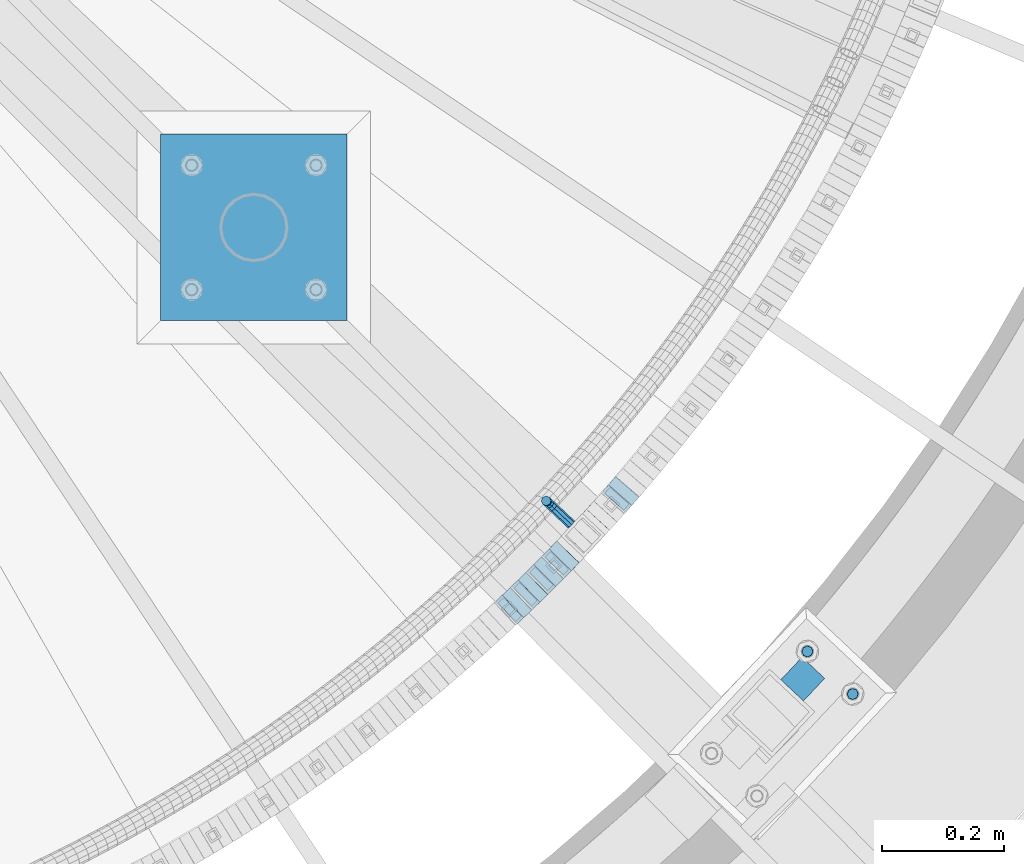
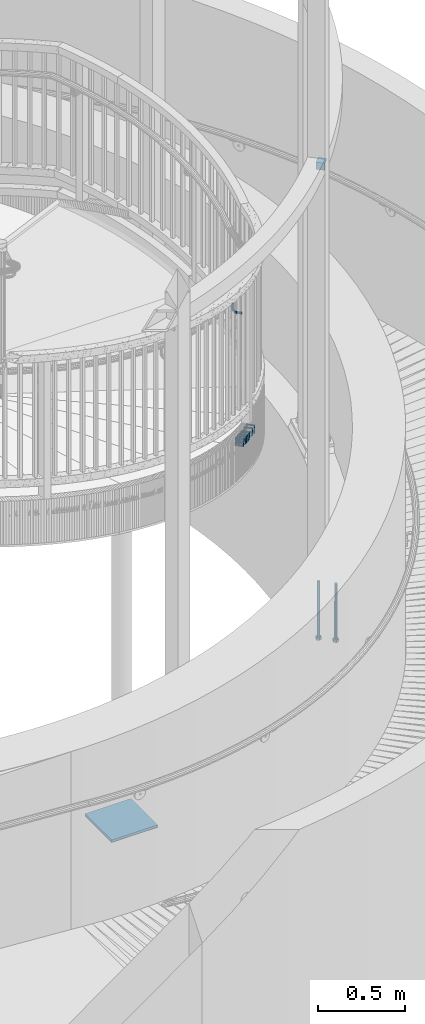
# One storey, part 492 of 975: 14 beams.
"""IFC2X3 building model written with IfcOpenShell, lengths in millimetres."""

from ifc_helpers import new_model, si_unit, frame, origin_with_axes, place, context, subcontext, project, spatial, faceted_brep, material, type_object, element, save


model = new_model("IFC2X3")

# Units and contexts
model_context = context("Model", 3, precision=1e-05, world=origin_with_axes())
body_context = subcontext(model_context, "Body", "Model", "MODEL_VIEW")
ifc_project = project(units=[si_unit("LENGTHUNIT", "METRE", prefix="MILLI"), si_unit("AREAUNIT", "SQUARE_METRE"), si_unit("VOLUMEUNIT", "CUBIC_METRE"), si_unit("MASSUNIT", "GRAM", prefix="KILO"), si_unit("TIMEUNIT", "SECOND"), si_unit("PLANEANGLEUNIT", "RADIAN"), si_unit("SOLIDANGLEUNIT", "STERADIAN"), si_unit("THERMODYNAMICTEMPERATUREUNIT", "DEGREE_CELSIUS"), si_unit("LUMINOUSINTENSITYUNIT", "LUMEN")], contexts=[model_context])

# Site, building, storey
site_placement = place(None, origin_with_axes())
site = spatial("IfcSite", under=ifc_project, at=site_placement, CompositionType="ELEMENT")
building_placement = place(site_placement, origin_with_axes())
building = spatial("IfcBuilding", under=site, at=building_placement, Name="Undefined", CompositionType="ELEMENT")
storey_placement = place(building_placement, origin_with_axes())
storey = spatial("IfcBuildingStorey", under=building, at=storey_placement, Name="Undefined", CompositionType="ELEMENT", Elevation=0.0)

# Beams
ifc_material_1 = material(Name="STEEL/A36")
beam_type_1 = type_object("IfcBeamType", PredefinedType="NOTDEFINED")
beam_1_placement = place(storey_placement, frame((36808.9338042328, 1456.90756596393, 3379.82813871674), z_axis=(0.0, 0.0, 1.0), x_axis=(-0.728868487009021, 0.684653729008453, 0.0)))
element("IfcBeam", 1, at=beam_1_placement, inside=storey, type_object=beam_type_1, material=ifc_material_1, Name="BRACKET", context=body_context, shape_type="Brep", body=[
    faceted_brep([(-4.22995071858168e-07, -7.93750000000728, 0.0), (-2.99107341561466e-07, -5.61266007567065, -5.61266007566792), (31.7499842270954, -5.6126618385606, -5.6126600757234), (31.7499840980236, -7.93750176289177, -5.54791768081486e-11), (-1.09139364212751e-11, 1.81898940354586e-12, -7.9375), (31.7499845387247, -1.7628881323617e-06, -7.93750000005548), (2.99089151667431e-07, 5.61266007567428, -5.61266007566792), (31.7499848503612, 5.61265831278433, -5.6126600757234), (4.22980519942939e-07, 7.93750000001091, 0.0), (31.7499849794513, 7.93749823711914, -5.54791768081486e-11), (2.99089151667431e-07, 5.61266007567428, 5.61266007566792), (31.7499848503794, 5.61265831278433, 5.61266007561244), (-1.09139364212751e-11, 1.81898940354586e-12, 7.9375), (31.7499845387538, -1.7628881323617e-06, 7.93749999994452), (-2.99107341561466e-07, -5.61266007567065, 5.61266007566792), (31.7499842271172, -5.6126618385606, 5.61266007561244), (44.5076933192395, -2.47124626184814e-06, -5.39983394420233), (43.618015285665, -5.61266249752225, -3.25196192174644), (41.4701431341346, -7.93750230259684, 1.9334598451087), (39.322271240766, -5.61266225900181, 7.11888161196475), (38.432593830461, -2.1339365048334e-06, 9.26675363442064), (39.3222718640282, 5.61265789233948, 7.11888161196475), (41.4701440155623, 7.93749769741771, 1.9334598451087), (43.6180159089272, 5.61265765382268, -3.25196192174644), (53.6792468227941, 5.61265709518557, 3.47073764605557), (55.32315658683, -3.07176742353477e-06, 1.82682757038583), (49.7104969518768, 7.93749723988003, 7.43948764606012), (45.7417468228014, 5.61265753590487, 11.4082376460638), (44.0978364355033, -2.44848706643097e-06, 13.0521477217335), (45.7417461995356, -5.61266261544006, 11.4082376460638), (49.7104960704528, -7.93750276013816, 7.43948764606012), (53.6792461995283, -5.612663056163, 3.47073764605648), (60.4019463906188, 5.61265672191075, 13.5319685599115), (62.5498181014409, -3.47302193404175e-06, 12.6422908379673), (55.2165247528465, 7.93749693416248, 15.6798405823693), (50.0311028569122, 5.61265729774459, 17.8277126048279), (47.8832305228243, -2.65866765403189e-06, 18.7173903267721), (50.03110223365, -5.61266285360034, 17.8277126048279), (55.2165238714188, -7.93750306585207, 15.6798405823693), (60.4019457673567, -5.61266342943782, 13.5319685599115), (62.7626445446149, 5.61265659083438, 25.3999996184748), (65.0874841573168, -3.61392449121922e-06, 25.3999996184748), (57.1499845980288, 7.93749682680573, 25.3999996184748), (51.5373243932772, 5.61265721410746, 25.3999996184748), (49.2124841573132, -2.73247496807016e-06, 25.3999996184748), (51.5373237700151, -5.61266293723384, 25.3999996184748), (57.1499837166011, -7.93750317320519, 25.3999996184748), (62.7626439213527, -5.61266356051055, 25.3999996184748), (65.0874827799671, -8.13710357761011e-07, 63.5532656203741), (62.7626427854739, -5.61266086031537, 61.7133802904182), (57.1499826807376, -7.93750071448449, 60.9512776088477), (51.5373226341253, -5.61266071998034, 61.7133869906074), (49.2124827799453, -6.15244061918929e-07, 63.5532750958728), (51.5373227744385, 5.61265943136095, 65.3931604258296), (57.1499828791711, 7.93749928552643, 66.1552631073992), (62.7626429257907, 5.61265929102228, 65.3931537256394)], [[[0, 1, 2, 3]], [[1, 4, 5, 2]], [[4, 6, 7, 5]], [[6, 8, 9, 7]], [[8, 10, 11, 9]], [[10, 12, 13, 11]], [[12, 14, 15, 13]], [[14, 0, 3, 15]], [[14, 12, 10, 8, 6, 4, 1, 0]], [[2, 5, 16, 17]], [[3, 2, 17, 18]], [[15, 3, 18, 19]], [[13, 15, 19, 20]], [[11, 13, 20, 21]], [[9, 11, 21, 22]], [[7, 9, 22, 23]], [[5, 7, 23, 16]], [[23, 24, 25, 16]], [[22, 26, 24, 23]], [[21, 27, 26, 22]], [[20, 28, 27, 21]], [[19, 29, 28, 20]], [[18, 30, 29, 19]], [[17, 31, 30, 18]], [[16, 25, 31, 17]], [[24, 32, 33, 25]], [[26, 34, 32, 24]], [[27, 35, 34, 26]], [[28, 36, 35, 27]], [[29, 37, 36, 28]], [[30, 38, 37, 29]], [[31, 39, 38, 30]], [[25, 33, 39, 31]], [[32, 40, 41, 33]], [[34, 42, 40, 32]], [[35, 43, 42, 34]], [[36, 44, 43, 35]], [[37, 45, 44, 36]], [[38, 46, 45, 37]], [[39, 47, 46, 38]], [[33, 41, 47, 39]], [[47, 41, 48, 49]], [[46, 47, 49, 50]], [[45, 46, 50, 51]], [[44, 45, 51, 52]], [[43, 44, 52, 53]], [[42, 43, 53, 54]], [[40, 42, 54, 55]], [[41, 40, 55, 48]], [[54, 53, 52, 51, 50, 49, 48, 55]]]),
])
ifc_material_2 = material()
beam_type_2 = type_object("IfcBeamType", Name="HSS2X2X.188_TUBES", PredefinedType="NOTDEFINED")
beam_2_placement = place(storey_placement, frame((36707.4498664089, 1318.3081771136, 2596.92843765627), z_axis=(-0.690210929024432, 0.723608232025611, 0.0), x_axis=(0.688611869936636, 0.656829783939555, -0.307226833971721)))
element("IfcBeam", 2, at=beam_2_placement, inside=storey, type_object=beam_type_2, material=ifc_material_2, Name="WALL", ObjectType="HSS2X2X.188_TUBES", context=body_context, shape_type="Brep", body=[
    faceted_brep([(0.0, 20.6374999999753, -20.6375000000298), (0.0, -20.6375000000153, -20.6375000000153), (18.8814724002259, -20.6375000000171, -20.6374999999753), (18.8814724002277, 20.6374999999916, -20.6374999999716), (0.0, -20.6374999999825, 20.6375000000335), (18.8814724002368, -20.6375000000062, 20.6375000000298), (0.0, 20.6375000000116, 20.6375000000189), (18.8814724002386, 20.6375000000025, 20.6375000000262), (0.0, 25.3999999999724, -25.4000000000342), (0.0, 25.400000000016, 25.4000000000196), (18.8814724002386, 25.4000000000051, 25.4000000000269), (18.8814724002277, 25.3999999999905, -25.399999999976), (0.0, -25.399999999976, 25.4000000000378), (18.8814724002368, -25.4000000000051, 25.4000000000269), (0.0, -25.400000000016, -25.4000000000196), (18.8814724002259, -25.4000000000196, -25.399999999976)], [[[0, 1, 2, 3]], [[1, 4, 5, 2]], [[4, 6, 7, 5]], [[6, 0, 3, 7]], [[8, 9, 10, 11]], [[9, 12, 13, 10]], [[12, 14, 15, 13]], [[14, 8, 11, 15]], [[13, 15, 11, 10], [5, 7, 3, 2]], [[14, 12, 9, 8], [6, 4, 1, 0]]]),
])
beam_3_placement = place(storey_placement, frame((36733.5951510392, 1343.3146411153, 2585.3985752978), z_axis=(-0.698672998973499, 0.715441150972864, 0.0), x_axis=(0.681680911153154, 0.665704015149544, -0.303561031068189)))
element("IfcBeam", 3, at=beam_3_placement, inside=storey, type_object=beam_type_2, material=ifc_material_2, Name="WALL", ObjectType="HSS2X2X.188_TUBES", context=body_context, shape_type="Brep", body=[
    faceted_brep([(0.0, 20.6374999999753, -20.6375000000298), (0.0, -20.6375000000153, -20.6375000000153), (18.7771137292038, -20.637500000008, -20.6374999999862), (18.777113729182, 20.6375000000062, -20.6375000000189), (0.0, -20.6374999999825, 20.6375000000335), (18.7771137291729, -20.6374999999916, 20.6374999999753), (0.0, 20.6375000000116, 20.6375000000189), (18.7771137291529, 20.6375000000207, 20.6374999999389), (0.0, 25.3999999999724, -25.4000000000342), (0.0, 25.400000000016, 25.4000000000196), (18.7771137291475, 25.4000000000251, 25.3999999999287), (18.7771137291857, 25.4000000000051, -25.4000000000196), (0.0, -25.399999999976, 25.4000000000378), (18.7771137291711, -25.3999999999905, 25.3999999999724), (0.0, -25.400000000016, -25.4000000000196), (18.7771137292129, -25.4000000000124, -25.3999999999724)], [[[0, 1, 2, 3]], [[1, 4, 5, 2]], [[4, 6, 7, 5]], [[6, 0, 3, 7]], [[8, 9, 10, 11]], [[9, 12, 13, 10]], [[12, 14, 15, 13]], [[14, 8, 11, 15]], [[13, 15, 11, 10], [5, 7, 3, 2]], [[14, 12, 9, 8], [6, 4, 1, 0]]]),
])
beam_4_placement = place(storey_placement, frame((36746.5667742288, 1355.85444922879, 2579.74724148177), z_axis=(-0.707106781186601, 0.707106781186494, 2.36468622460961e-14), x_axis=(0.672385013200501, 0.672385013200525, -0.3095105620923)))
element("IfcBeam", 4, at=beam_4_placement, inside=storey, type_object=beam_type_2, material=ifc_material_2, Name="WALL", ObjectType="HSS2X2X.188_TUBES", context=body_context, shape_type="Brep", body=[
    faceted_brep([(0.0, 20.6374999999753, -20.6375000000298), (0.0, -20.6375000000153, -20.6375000000153), (18.7416648140024, -20.6375000000153, -20.6374999999825), (18.7416648139188, 20.6375000000189, -20.6375000000298), (0.0, -20.6374999999825, 20.6375000000335), (18.7416648140097, -20.6375000000189, 20.6375000000226), (0.0, 20.6375000000116, 20.6375000000189), (18.741664813926, 20.6375000000153, 20.6374999999753), (0.0, 25.3999999999724, -25.4000000000342), (0.0, 25.400000000016, 25.4000000000196), (18.7416648139224, 25.4000000000196, 25.3999999999687), (18.7416648139042, 25.4000000000233, -25.4000000000378), (0.0, -25.399999999976, 25.4000000000378), (18.7416648140133, -25.4000000000215, 25.4000000000269), (0.0, -25.400000000016, -25.4000000000196), (18.7416648140133, -25.4000000000196, -25.399999999976)], [[[0, 1, 2, 3]], [[1, 4, 5, 2]], [[4, 6, 7, 5]], [[6, 0, 3, 7]], [[8, 9, 10, 11]], [[9, 12, 13, 10]], [[12, 14, 15, 13]], [[14, 8, 11, 15]], [[13, 15, 11, 10], [5, 7, 3, 2]], [[14, 12, 9, 8], [6, 4, 1, 0]]]),
])
beam_5_placement = place(storey_placement, frame((36759.3657643646, 1368.61061814994, 2573.89871465884), z_axis=(-0.709896124735859, 0.704306390773937, 2.16259650187566e-10), x_axis=(0.671067713910047, 0.676393648909331, -0.3035782519593)))
element("IfcBeam", 5, at=beam_5_placement, inside=storey, type_object=beam_type_2, material=ifc_material_2, Name="WALL", ObjectType="HSS2X2X.188_TUBES", context=body_context, shape_type="Brep", body=[
    faceted_brep([(0.0, 20.6374999999753, -20.6375000000298), (0.0, -20.6375000000153, -20.6375000000153), (18.7771137292038, -20.637500000008, -20.6374999999862), (18.777113729182, 20.6375000000062, -20.6375000000189), (0.0, -20.6374999999825, 20.6375000000335), (18.7771137291729, -20.6374999999916, 20.6374999999753), (0.0, 20.6375000000116, 20.6375000000189), (18.7771137291529, 20.6375000000207, 20.6374999999389), (0.0, 25.3999999999724, -25.4000000000342), (0.0, 25.400000000016, 25.4000000000196), (18.7771137291475, 25.4000000000251, 25.3999999999287), (18.7771137291857, 25.4000000000051, -25.4000000000196), (0.0, -25.399999999976, 25.4000000000378), (18.7771137291711, -25.3999999999905, 25.3999999999724), (0.0, -25.400000000016, -25.4000000000196), (18.7771137292129, -25.4000000000124, -25.3999999999724)], [[[0, 1, 2, 3]], [[1, 4, 5, 2]], [[4, 6, 7, 5]], [[6, 0, 3, 7]], [[8, 9, 10, 11]], [[9, 12, 13, 10]], [[12, 14, 15, 13]], [[14, 8, 11, 15]], [[13, 15, 11, 10], [5, 7, 3, 2]], [[14, 12, 9, 8], [6, 4, 1, 0]]]),
])
beam_6_placement = place(storey_placement, frame((36784.7601860777, 1394.18123807056, 2562.48968881059), z_axis=(-0.718153275385914, 0.695884956765472, 1.38664290716406e-10), x_axis=(0.663290998429885, 0.684516310443672, -0.302460695196035)))
element("IfcBeam", 6, at=beam_6_placement, inside=storey, type_object=beam_type_2, material=ifc_material_2, Name="WALL", ObjectType="HSS2X2X.188_TUBES", context=body_context, shape_type="Brep", body=[
    faceted_brep([(0.0, 20.6374999999753, -20.6375000000298), (0.0, -20.6375000000153, -20.6375000000153), (18.8480768248774, -20.6374999999716, -20.6375000000735), (18.8480768249356, 20.6375000000153, -20.6375000000226), (0.0, -20.6374999999825, 20.6375000000335), (18.8480768249283, -20.6374999999935, 20.6374999999716), (0.0, 20.6375000000116, 20.6375000000189), (18.8480768249865, 20.6374999999935, 20.6375000000262), (0.0, 25.3999999999724, -25.4000000000342), (0.0, 25.400000000016, 25.4000000000196), (18.848076825001, 25.3999999999887, 25.4000000000378), (18.8480768249392, 25.4000000000142, -25.4000000000233), (0.0, -25.399999999976, 25.4000000000378), (18.8480768249283, -25.399999999996, 25.3999999999833), (0.0, -25.400000000016, -25.4000000000196), (18.8480768248664, -25.3999999999687, -25.4000000000779)], [[[0, 1, 2, 3]], [[1, 4, 5, 2]], [[4, 6, 7, 5]], [[6, 0, 3, 7]], [[8, 9, 10, 11]], [[9, 12, 13, 10]], [[12, 14, 15, 13]], [[14, 8, 11, 15]], [[13, 15, 11, 10], [5, 7, 3, 2]], [[14, 12, 9, 8], [6, 4, 1, 0]]]),
])
beam_7_placement = place(storey_placement, frame((36797.3244793935, 1407.05776178885, 2556.84658599993), z_axis=(-0.723737544936702, 0.690075333604234, 7.89900695963296e-11), x_axis=(0.65620768606595, 0.6882178170692, -0.309431267031107)))
element("IfcBeam", 7, at=beam_7_placement, inside=storey, type_object=beam_type_2, material=ifc_material_2, Name="WALL", ObjectType="HSS2X2X.188_TUBES", context=body_context, shape_type="Brep", body=[
    faceted_brep([(0.0, 20.6374999999753, -20.6375000000298), (0.0, -20.6375000000153, -20.6375000000153), (18.7416648140024, -20.6375000000153, -20.6374999999825), (18.7416648139188, 20.6375000000189, -20.6375000000298), (0.0, -20.6374999999825, 20.6375000000335), (18.7416648140097, -20.6375000000189, 20.6375000000226), (0.0, 20.6375000000116, 20.6375000000189), (18.741664813926, 20.6375000000153, 20.6374999999753), (0.0, 25.3999999999724, -25.4000000000342), (0.0, 25.400000000016, 25.4000000000196), (18.7416648139224, 25.4000000000196, 25.3999999999687), (18.7416648139042, 25.4000000000233, -25.4000000000378), (0.0, -25.399999999976, 25.4000000000378), (18.7416648140133, -25.4000000000215, 25.4000000000269), (0.0, -25.400000000016, -25.4000000000196), (18.7416648140133, -25.4000000000196, -25.399999999976)], [[[0, 1, 2, 3]], [[1, 4, 5, 2]], [[4, 6, 7, 5]], [[6, 0, 3, 7]], [[8, 9, 10, 11]], [[9, 12, 13, 10]], [[12, 14, 15, 13]], [[14, 8, 11, 15]], [[13, 15, 11, 10], [5, 7, 3, 2]], [[14, 12, 9, 8], [6, 4, 1, 0]]]),
])
beam_8_placement = place(storey_placement, frame((36846.6768580576, 1459.47690570758, 2533.94462368442), z_axis=(-0.73994007337864, 0.672672794015346, 7.91187630966307e-11), x_axis=(0.639711199977634, 0.7036823199754, -0.309193746989189)))
element("IfcBeam", 8, at=beam_8_placement, inside=storey, type_object=beam_type_2, material=ifc_material_2, Name="WALL", ObjectType="HSS2X2X.188_TUBES", context=body_context, shape_type="Brep", body=[
    faceted_brep([(0.0, 20.6374999999753, -20.6375000000298), (0.0, -20.6375000000153, -20.6375000000153), (18.7555325170906, -20.6374999999916, -20.6374999999971), (18.7555325171452, 20.637499999988, -20.6374999999571), (0.0, -20.6374999999825, 20.6375000000335), (18.7555325170615, -20.6374999999844, 20.6374999999716), (0.0, 20.6375000000116, 20.6375000000189), (18.7555325171015, 20.6374999999953, 20.637500000008), (0.0, 25.3999999999724, -25.4000000000342), (0.0, 25.400000000016, 25.4000000000196), (18.7555325171015, 25.399999999996, 25.4000000000051), (18.7555325171488, 25.3999999999851, -25.3999999999505), (0.0, -25.399999999976, 25.4000000000378), (18.755532517047, -25.3999999999814, 25.3999999999578), (0.0, -25.400000000016, -25.4000000000196), (18.7555325170979, -25.3999999999924, -25.3999999999978)], [[[0, 1, 2, 3]], [[1, 4, 5, 2]], [[4, 6, 7, 5]], [[6, 0, 3, 7]], [[8, 9, 10, 11]], [[9, 12, 13, 10]], [[12, 14, 15, 13]], [[14, 8, 11, 15]], [[13, 15, 11, 10], [5, 7, 3, 2]], [[14, 12, 9, 8], [6, 4, 1, 0]]]),
])
beam_9_placement = place(storey_placement, frame((36882.8415954826, 1499.59825373725, 2516.74259520954), z_axis=(-0.750491265131667, 0.660880368115947, 0.0), x_axis=(0.628549392665014, 0.713776428619576, -0.308948006835335)))
element("IfcBeam", 9, at=beam_9_placement, inside=storey, type_object=beam_type_2, material=ifc_material_2, Name="WALL", ObjectType="HSS2X2X.188_TUBES", context=body_context, shape_type="Brep", body=[
    faceted_brep([(0.0, 20.6374999999753, -20.6375000000298), (0.0, -20.6375000000153, -20.6375000000153), (18.767258723612, -20.6375000000025, -20.6374999999862), (18.7672587236229, 20.6374999999953, -20.637499999968), (0.0, -20.6374999999825, 20.6375000000335), (18.767258723612, -20.6375000000135, 20.6375000000153), (0.0, 20.6375000000116, 20.6375000000189), (18.7672587236266, 20.6374999999844, 20.6375000000371), (0.0, 25.3999999999724, -25.4000000000342), (0.0, 25.400000000016, 25.4000000000196), (18.7672587236302, 25.3999999999814, 25.4000000000342), (18.7672587236229, 25.399999999996, -25.3999999999687), (0.0, -25.399999999976, 25.4000000000378), (18.7672587236157, -25.4000000000142, 25.400000000016), (0.0, -25.400000000016, -25.4000000000196), (18.767258723612, -25.4000000000015, -25.3999999999905)], [[[0, 1, 2, 3]], [[1, 4, 5, 2]], [[4, 6, 7, 5]], [[6, 0, 3, 7]], [[8, 9, 10, 11]], [[9, 12, 13, 10]], [[12, 14, 15, 13]], [[14, 8, 11, 15]], [[13, 15, 11, 10], [5, 7, 3, 2]], [[14, 12, 9, 8], [6, 4, 1, 0]]]),
])
beam_type_3 = type_object("IfcBeamType", Name="L2X2X1/4", PredefinedType="NOTDEFINED")
beam_10_placement = place(storey_placement, frame((37204.8603869909, 1187.51939198126, 4445.0), z_axis=(0.684674324933948, 0.728849139929686, 0.0), x_axis=(-0.728849139929688, 0.684674324933946, 0.0)))
element("IfcBeam", 10, at=beam_10_placement, inside=storey, type_object=beam_type_3, material=ifc_material_1, Name="ANGLE", ObjectType="L2X2X1/4", context=body_context, shape_type="Brep", body=[
    faceted_brep([(0.0, 25.3999999999724, -25.4000000000342), (0.0, 25.400000000016, 25.4000000000196), (50.8000000000102, 25.3999999999996, 25.4000000000015), (50.7999999999411, 25.3999999999996, -25.4000000000487), (3.27418092638254e-11, 19.0500000000002, 25.4000000000269), (50.8000000000102, 19.0500000000002, 25.4000000000015), (-2.5465851649642e-11, 19.0500000000002, -19.0500000000211), (50.7999999999483, 19.0500000000002, -19.0500000000429), (-2.5465851649642e-11, -25.3999999999996, -19.0500000000211), (50.7999999999483, -25.3999999999996, -19.0500000000429), (0.0, -25.400000000016, -25.4000000000196), (50.7999999999411, -25.3999999999996, -25.4000000000487)], [[[0, 1, 2, 3]], [[1, 4, 5, 2]], [[4, 6, 7, 5]], [[6, 8, 9, 7]], [[8, 10, 11, 9]], [[10, 0, 3, 11]], [[5, 7, 9, 11, 3, 2]], [[10, 8, 6, 4, 1, 0]]]),
])
beam_type_4 = type_object("IfcBeamType", PredefinedType="NOTDEFINED")
beam_11_placement = place(storey_placement, frame((36289.6171351652, 1790.34027501151, -282.577138628192), z_axis=(-0.999999999999998, 6.90000001668524e-08, 0.0), x_axis=(5.99999145147521e-09, 0.999999999901537, 1.40329999985367e-05)))
element("IfcBeam", 11, at=beam_11_placement, inside=storey, type_object=beam_type_4, material=ifc_material_1, Name="PLATE", context=body_context, shape_type="Brep", body=[
    faceted_brep([(0.0, 9.52499999999964, -152.4), (0.0, 9.52499999999964, 152.4), (304.799999999152, 9.52499999999964, 152.4), (304.799999999152, 9.52499999999964, -152.4), (0.0, -9.52499999999964, 152.4), (304.799999999152, -9.52499999999964, 152.4), (0.0, -9.52499999999964, -152.4), (304.799999999152, -9.52499999999964, -152.4)], [[[0, 1, 2, 3]], [[1, 4, 5, 2]], [[4, 6, 7, 5]], [[6, 0, 3, 7]], [[5, 7, 3, 2]], [[6, 4, 1, 0]]]),
])
ifc_material_3 = material(Name="STEEL/F1554-36")
beam_type_5 = type_object("IfcBeamType", PredefinedType="NOTDEFINED")
beam_12_placement = place(storey_placement, frame((37193.920938283, 1250.0699954707, 1371.6), z_axis=(-0.684674324933948, -0.728849139929686, 0.0), x_axis=(0.0, 0.0, -1.0)))
element("IfcBeam", 12, at=beam_12_placement, inside=storey, type_object=beam_type_5, material=ifc_material_3, Name="HEADED_ANCHOR_BOLT", context=body_context, shape_type="Brep", body=[
    faceted_brep([(260.34375, -9.13000011445183, 15.8100004195221), (260.34375, -18.2600002289691, -1.45519152283669e-11), (279.393749999999, -18.2600002289691, -1.45519152283669e-11), (279.393749999999, -9.13000011445183, 15.8100004195221), (260.34375, 9.13000011451732, 15.8100004195403), (279.393749999999, 9.13000011451732, 15.8100004195403), (260.34375, 18.2600002289728, 1.81898940354586e-11), (279.393749999999, 18.2600002289728, 1.81898940354586e-11), (260.34375, 9.13000011445547, -15.8100004195221), (279.393749999999, 9.13000011445547, -15.8100004195221), (260.34375, -9.13000011451732, -15.8100004195367), (279.393749999999, -9.13000011451732, -15.8100004195367), (260.34375, -4.47768005528269, 9.29799844174704), (260.34375, -8.06850066050174, 6.43441456486471), (260.34375, -10.0612557562381, 2.29641597050068), (260.34375, -10.0612557562454, -2.29641597051523), (260.34375, -8.06850066052721, -6.43441456487926), (260.34375, -4.47768005531907, -9.29799844175068), (260.34375, -1.81898940354586e-11, -10.319999694766), (260.34375, 4.47768005528633, -9.2979984417434), (260.34375, 8.06850066050174, -6.43441456486471), (260.34375, 10.0612557562381, -2.29641597050068), (260.34375, 10.0612557562454, 2.29641597051886), (260.34375, 8.06850066052357, 6.4344145648829), (260.34375, 4.47768005532271, 9.29799844175432), (260.34375, 2.18278728425503e-11, 10.3199996947696), (279.393749999999, 2.18278728425503e-11, 10.3199996947696), (279.393749999999, -4.47768005528269, 9.29799844174704), (279.393749999999, -8.06850066050174, 6.43441456486471), (279.393749999999, -10.0612557562381, 2.29641597050068), (279.393749999999, -10.0612557562454, -2.29641597051523), (279.393749999999, -8.06850066052721, -6.43441456487926), (279.393749999999, -4.47768005531907, -9.29799844175068), (279.393749999999, -1.81898940354586e-11, -10.319999694766), (279.393749999999, 4.47768005528633, -9.2979984417434), (279.393749999999, 8.06850066050174, -6.43441456486471), (279.393749999999, 10.0612557562381, -2.29641597050068), (279.393749999999, 10.0612557562454, 2.29641597051886), (279.393749999999, 8.06850066052357, 6.4344145648829), (279.393749999999, 4.47768005532271, 9.29799844175432), (0.0, -6.73519209080223, 6.73519209080186), (0.0, -9.52499999999964, 0.0), (279.400000000001, -9.52499999999782, -3.63797880709171e-12), (279.400000000001, -6.73519209079313, 6.73519209079313), (-9.87109982941227e-13, -1.20792265079217e-13, 9.52499961853027), (279.400000000001, 1.09139364212751e-11, 9.52499999999054), (0.0, 6.73519209080223, 6.73519209080186), (279.400000000001, 6.73519209081132, 6.73519209079677), (0.0, 9.52499999999964, 0.0), (279.400000000001, 9.52500000000146, 3.63797880709171e-12), (0.0, 6.73519209080223, -6.73519209080186), (279.400000000001, 6.73519209079677, -6.73519209079313), (2.95075507493764e-12, -1.20792265079217e-13, -9.52499961853027), (279.400000000001, -1.09139364212751e-11, -9.5249999999869), (-126.99791499542, -6.36396103070001, 6.3639610306418), (-126.99791499542, 1.81898940354586e-11, 8.99999999995271), (-126.99791499542, 6.36396103072184, 6.36396103065272), (-126.99791499542, 9.00000000004366, 1.09139364212751e-11), (-126.99791499542, 6.36396103069637, -6.3639610306418), (-126.99791499542, -1.81898940354586e-11, -8.99999999995271), (-126.99791499542, -6.36396103072184, -6.36396103064908), (-126.99791499542, -9.00000000004002, -7.27595761418343e-12), (0.0149743263646087, 6.36396103067818, -6.36396103067909), (0.0149743263646087, 0.0, -9.0), (0.0149743263646087, -6.36396103067818, -6.36396103067909), (0.0149743263987148, -8.9999995411581, -1.00796984270346e-06), (0.0149743263646087, -6.36396103067818, 6.36396103067909), (0.0149743263646087, 0.0, 9.0), (0.0149743263646087, 6.36396103067818, 6.36396103067909), (0.0149743263987148, 9.0000004588419, -1.00796984270346e-06), (0.0, -6.73519209080223, -6.73519209080186), (279.400000000001, -6.73519209080769, -6.73519209079677)], [[[0, 1, 2, 3]], [[4, 0, 3, 5]], [[6, 4, 5, 7]], [[8, 6, 7, 9]], [[10, 8, 9, 11]], [[0, 4, 6, 8, 10, 1], [12, 13, 14, 15, 16, 17, 18, 19, 20, 21, 22, 23, 24, 25]], [[12, 25, 26, 27]], [[13, 12, 27, 28]], [[14, 13, 28, 29]], [[15, 14, 29, 30]], [[16, 15, 30, 31]], [[17, 16, 31, 32]], [[18, 17, 32, 33]], [[19, 18, 33, 34]], [[20, 19, 34, 35]], [[21, 20, 35, 36]], [[22, 21, 36, 37]], [[23, 22, 37, 38]], [[24, 23, 38, 39]], [[25, 24, 39, 26]], [[9, 7, 5, 3, 2, 11], [38, 37, 36, 35, 34, 33, 32, 31, 30, 29, 28, 27, 26, 39]], [[1, 10, 11, 2]], [[40, 41, 42, 43]], [[44, 40, 43, 45]], [[46, 44, 45, 47]], [[48, 46, 47, 49]], [[50, 48, 49, 51]], [[52, 50, 51, 53]], [[54, 55, 56, 57, 58, 59, 60, 61]], [[59, 58, 62, 63]], [[60, 59, 63, 64]], [[61, 60, 64, 65]], [[54, 61, 65, 66]], [[55, 54, 66, 67]], [[56, 55, 67, 68]], [[57, 56, 68, 69]], [[58, 57, 69, 62]], [[40, 44, 46, 48, 50, 52, 70, 41], [68, 67, 66, 65, 64, 63, 62, 69]], [[41, 70, 71, 42]], [[53, 51, 49, 47, 45, 43, 42, 71]], [[70, 52, 53, 71]]]),
])
beam_13_placement = place(storey_placement, frame((37267.9720150788, 1180.50708850571, 1371.6), z_axis=(0.684674324933948, 0.728849139929686, 0.0), x_axis=(0.0, 0.0, -1.0)))
element("IfcBeam", 13, at=beam_13_placement, inside=storey, type_object=beam_type_5, material=ifc_material_3, Name="HEADED_ANCHOR_BOLT", context=body_context, shape_type="Brep", body=[
    faceted_brep([(260.34375, -9.13000011445183, 15.8100004195221), (260.34375, -18.2600002289691, -1.45519152283669e-11), (279.393749999999, -18.2600002289691, -1.45519152283669e-11), (279.393749999999, -9.13000011445183, 15.8100004195221), (260.34375, 9.13000011451732, 15.8100004195403), (279.393749999999, 9.13000011451732, 15.8100004195403), (260.34375, 18.2600002289728, 1.81898940354586e-11), (279.393749999999, 18.2600002289728, 1.81898940354586e-11), (260.34375, 9.13000011445547, -15.8100004195221), (279.393749999999, 9.13000011445547, -15.8100004195221), (260.34375, -9.13000011451732, -15.8100004195367), (279.393749999999, -9.13000011451732, -15.8100004195367), (260.34375, -4.47768005528269, 9.29799844174704), (260.34375, -8.06850066050174, 6.43441456486471), (260.34375, -10.0612557562381, 2.29641597050068), (260.34375, -10.0612557562454, -2.29641597051523), (260.34375, -8.06850066052721, -6.43441456487926), (260.34375, -4.47768005531907, -9.29799844175068), (260.34375, -1.81898940354586e-11, -10.319999694766), (260.34375, 4.47768005528633, -9.2979984417434), (260.34375, 8.06850066050174, -6.43441456486471), (260.34375, 10.0612557562381, -2.29641597050068), (260.34375, 10.0612557562454, 2.29641597051886), (260.34375, 8.06850066052357, 6.4344145648829), (260.34375, 4.47768005532271, 9.29799844175432), (260.34375, 2.18278728425503e-11, 10.3199996947696), (279.393749999999, 2.18278728425503e-11, 10.3199996947696), (279.393749999999, -4.47768005528269, 9.29799844174704), (279.393749999999, -8.06850066050174, 6.43441456486471), (279.393749999999, -10.0612557562381, 2.29641597050068), (279.393749999999, -10.0612557562454, -2.29641597051523), (279.393749999999, -8.06850066052721, -6.43441456487926), (279.393749999999, -4.47768005531907, -9.29799844175068), (279.393749999999, -1.81898940354586e-11, -10.319999694766), (279.393749999999, 4.47768005528633, -9.2979984417434), (279.393749999999, 8.06850066050174, -6.43441456486471), (279.393749999999, 10.0612557562381, -2.29641597050068), (279.393749999999, 10.0612557562454, 2.29641597051886), (279.393749999999, 8.06850066052357, 6.4344145648829), (279.393749999999, 4.47768005532271, 9.29799844175432), (0.0, -6.73519209080223, 6.73519209080186), (0.0, -9.52499999999964, 0.0), (279.400000000001, -9.52499999999782, -3.63797880709171e-12), (279.400000000001, -6.73519209079313, 6.73519209079313), (-9.87109982941227e-13, -1.20792265079217e-13, 9.52499961853027), (279.400000000001, 1.09139364212751e-11, 9.52499999999054), (0.0, 6.73519209080223, 6.73519209080186), (279.400000000001, 6.73519209081132, 6.73519209079677), (0.0, 9.52499999999964, 0.0), (279.400000000001, 9.52500000000146, 3.63797880709171e-12), (0.0, 6.73519209080223, -6.73519209080186), (279.400000000001, 6.73519209079677, -6.73519209079313), (2.95075507493764e-12, -1.20792265079217e-13, -9.52499961853027), (279.400000000001, -1.09139364212751e-11, -9.5249999999869), (-126.99791499542, -6.36396103070001, 6.3639610306418), (-126.99791499542, 1.81898940354586e-11, 8.99999999995271), (-126.99791499542, 6.36396103072184, 6.36396103065272), (-126.99791499542, 9.00000000004366, 1.09139364212751e-11), (-126.99791499542, 6.36396103069637, -6.3639610306418), (-126.99791499542, -1.81898940354586e-11, -8.99999999995271), (-126.99791499542, -6.36396103072184, -6.36396103064908), (-126.99791499542, -9.00000000004002, -7.27595761418343e-12), (0.0149743263646087, 6.36396103067818, -6.36396103067909), (0.0149743263646087, 0.0, -9.0), (0.0149743263646087, -6.36396103067818, -6.36396103067909), (0.0149743263987148, -8.9999995411581, -1.00796984270346e-06), (0.0149743263646087, -6.36396103067818, 6.36396103067909), (0.0149743263646087, 0.0, 9.0), (0.0149743263646087, 6.36396103067818, 6.36396103067909), (0.0149743263987148, 9.0000004588419, -1.00796984270346e-06), (0.0, -6.73519209080223, -6.73519209080186), (279.400000000001, -6.73519209080769, -6.73519209079677)], [[[0, 1, 2, 3]], [[4, 0, 3, 5]], [[6, 4, 5, 7]], [[8, 6, 7, 9]], [[10, 8, 9, 11]], [[0, 4, 6, 8, 10, 1], [12, 13, 14, 15, 16, 17, 18, 19, 20, 21, 22, 23, 24, 25]], [[12, 25, 26, 27]], [[13, 12, 27, 28]], [[14, 13, 28, 29]], [[15, 14, 29, 30]], [[16, 15, 30, 31]], [[17, 16, 31, 32]], [[18, 17, 32, 33]], [[19, 18, 33, 34]], [[20, 19, 34, 35]], [[21, 20, 35, 36]], [[22, 21, 36, 37]], [[23, 22, 37, 38]], [[24, 23, 38, 39]], [[25, 24, 39, 26]], [[9, 7, 5, 3, 2, 11], [38, 37, 36, 35, 34, 33, 32, 31, 30, 29, 28, 27, 26, 39]], [[1, 10, 11, 2]], [[40, 41, 42, 43]], [[44, 40, 43, 45]], [[46, 44, 45, 47]], [[48, 46, 47, 49]], [[50, 48, 49, 51]], [[52, 50, 51, 53]], [[54, 55, 56, 57, 58, 59, 60, 61]], [[59, 58, 62, 63]], [[60, 59, 63, 64]], [[61, 60, 64, 65]], [[54, 61, 65, 66]], [[55, 54, 66, 67]], [[56, 55, 67, 68]], [[57, 56, 68, 69]], [[58, 57, 69, 62]], [[40, 44, 46, 48, 50, 52, 70, 41], [68, 67, 66, 65, 64, 63, 62, 69]], [[41, 70, 71, 42]], [[53, 51, 49, 47, 45, 43, 42, 71]], [[70, 52, 53, 71]]]),
])
beam_type_6 = type_object("IfcBeamType", PredefinedType="NOTDEFINED")
beam_14_placement = place(storey_placement, frame((36289.617402494, 1790.34038639825, -290.514638625534), z_axis=(-0.999999999999998, 6.90000001668524e-08, 0.0), x_axis=(5.99999145147521e-09, 0.999999999901537, 1.40329999985367e-05)))
element("IfcBeam", 14, at=beam_14_placement, inside=storey, type_object=beam_type_6, material=ifc_material_1, Name="TEMPLATE", context=body_context, shape_type="Brep", body=[
    faceted_brep([(0.0, 1.58750000000009, -152.4), (0.0, 1.58750000000009, 152.4), (304.799999999153, 1.58750000000001, 152.400000000001), (304.799999999153, 1.58750000000001, -152.400000000001), (0.0, -1.58750000000009, 152.4), (304.799999999153, -1.58750000000001, 152.400000000001), (0.0, -1.58750000000009, -152.4), (304.799999999153, -1.58750000000001, -152.400000000001)], [[[0, 1, 2, 3]], [[1, 4, 5, 2]], [[4, 6, 7, 5]], [[6, 0, 3, 7]], [[5, 7, 3, 2]], [[6, 4, 1, 0]]]),
])

save(model, "model.ifc")
